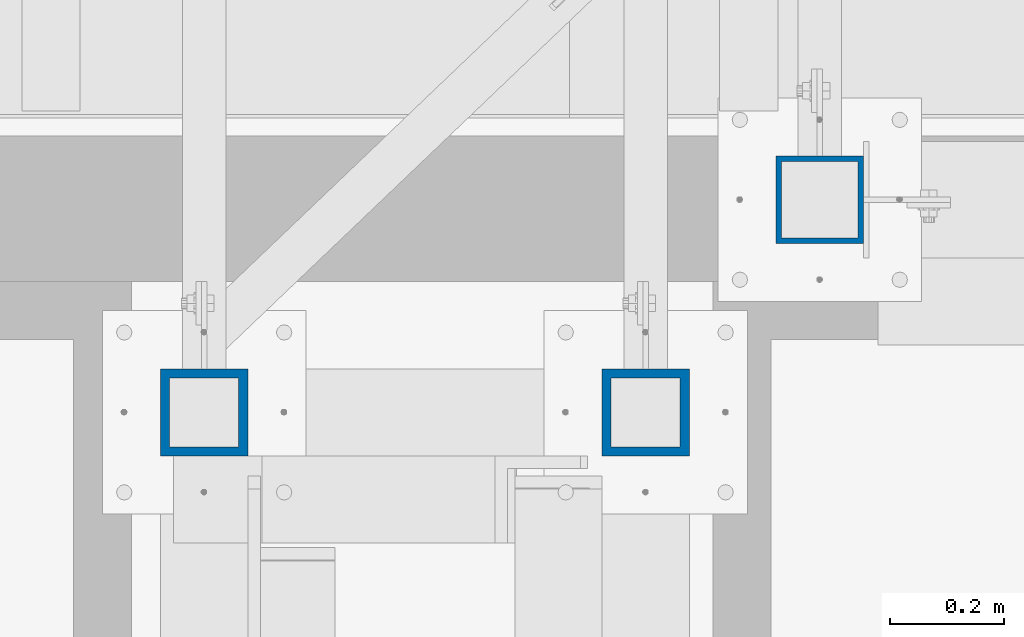
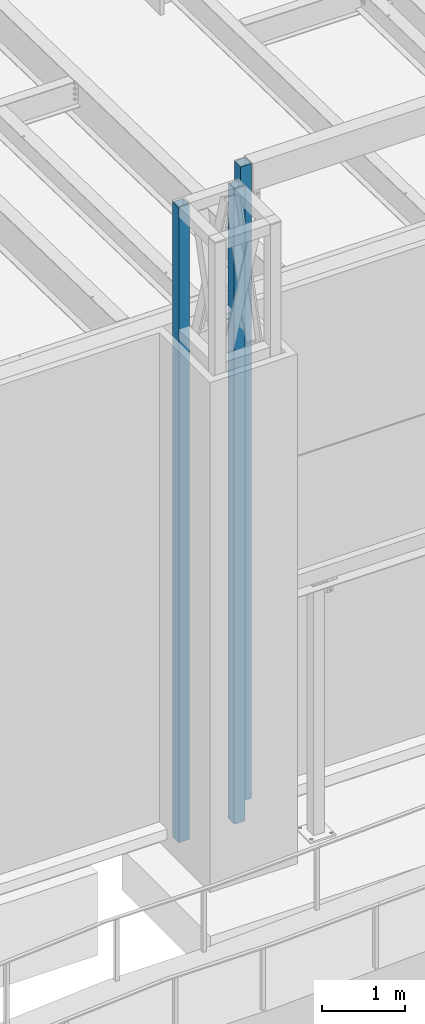
# One storey, part 880 of 1763: 3 columns, 2 elements without a shape of their own.
"""IFC2X3 building model written with IfcOpenShell, lengths in millimetres."""

from ifc_helpers import new_model, si_unit, frame, origin_with_axes, place, context, subcontext, project, spatial, faceted_brep, material, type_object, element, aggregate, save


model = new_model("IFC2X3")

# Units and contexts
model_context = context("Model", 3, precision=1e-05, world=origin_with_axes())
body_context = subcontext(model_context, "Body", "Model", "MODEL_VIEW")
ifc_project = project(units=[si_unit("LENGTHUNIT", "METRE", prefix="MILLI"), si_unit("AREAUNIT", "SQUARE_METRE"), si_unit("VOLUMEUNIT", "CUBIC_METRE"), si_unit("MASSUNIT", "GRAM", prefix="KILO"), si_unit("TIMEUNIT", "SECOND"), si_unit("PLANEANGLEUNIT", "RADIAN"), si_unit("SOLIDANGLEUNIT", "STERADIAN"), si_unit("THERMODYNAMICTEMPERATUREUNIT", "DEGREE_CELSIUS"), si_unit("LUMINOUSINTENSITYUNIT", "LUMEN")], contexts=[model_context])

# Site, building, storey
site_placement = place(None, origin_with_axes())
site = spatial("IfcSite", under=ifc_project, at=site_placement, CompositionType="ELEMENT")
building_placement = place(site_placement, origin_with_axes())
building = spatial("IfcBuilding", under=site, at=building_placement, Name="Undefined", CompositionType="ELEMENT")
storey_placement = place(building_placement, origin_with_axes())
storey = spatial("IfcBuildingStorey", under=building, at=storey_placement, Name="Undefined", CompositionType="ELEMENT", Elevation=0.0)

# Assembly, columns
assembly_1_placement = place(storey_placement, origin_with_axes())
assembly_1 = element("IfcElementAssembly", 1, at=assembly_1_placement, inside=storey, Name="FRAME", AssemblyPlace="NOTDEFINED", PredefinedType="RIGID_FRAME")
ifc_material = material()
column_type_1 = type_object("IfcColumnType", Name="HSS6X6X5/8", PredefinedType="NOTDEFINED")
column_1_placement = place(assembly_1_placement, frame((-69306.5116892775, -14579.5992675181, 5029.2), z_axis=(0.0, 1.0, 0.0), x_axis=(0.0, 0.0, 1.0)))
column_1 = element("IfcColumn", 2, at=column_1_placement, type_object=column_type_1, material=ifc_material, Name="COLUMN", ObjectType="HSS6X6X5/8", context=body_context, shape_type="Brep", body=[
    faceted_brep([(63.4999999999973, 60.3249999999971, -60.3250000000007), (63.4999999999973, -60.3249999999971, -60.3250000000007), (9429.74999873329, -60.3250000149637, -60.3250000000007), (9429.75000126672, 60.3249999850377, -60.3250000000007), (63.4999999999973, -60.3249999999971, 60.3250000000007), (9429.74999873329, -60.3250000149637, 60.3250000000007), (63.4999999999973, 60.3249999999971, 60.3250000000007), (9429.75000126672, 60.3249999850377, 60.3250000000007), (63.4999999999973, 76.1999999999971, -76.2000000000007), (63.4999999999973, 76.1999999999971, 76.2000000000007), (9429.75000000001, 76.1999999999971, 76.2000000000007), (9429.75000000001, 76.1999999999971, -76.2000000000007), (63.4999999999973, -76.1999999999971, 76.2000000000007), (9429.75000000001, -76.1999999999971, 76.2000000000007), (63.4999999999973, -76.1999999999971, -76.2000000000007), (9429.75000000001, -76.1999999999971, -76.2000000000007)], [[[0, 1, 2, 3]], [[1, 4, 5, 2]], [[4, 6, 7, 5]], [[6, 0, 3, 7]], [[8, 9, 10, 11]], [[9, 12, 13, 10]], [[12, 14, 15, 13]], [[14, 8, 11, 15]], [[13, 15, 11, 10], [5, 7, 3, 2]], [[14, 12, 9, 8], [6, 4, 1, 0]]]),
])
column_2_placement = place(assembly_1_placement, frame((-70078.03688459, -14579.5992675181, 5029.2), z_axis=(0.0, 1.0, 0.0), x_axis=(0.0, 0.0, 1.0)))
column_2 = element("IfcColumn", 3, at=column_2_placement, type_object=column_type_1, material=ifc_material, Name="COLUMN", ObjectType="HSS6X6X5/8", context=body_context, shape_type="Brep", body=[
    faceted_brep([(63.4999999999973, 60.3249999999971, -60.3250000000007), (63.4999999999973, -60.3249999999971, -60.3250000000007), (9429.74999873329, -60.3250000149637, -60.3250000000007), (9429.75000126672, 60.3249999850377, -60.3250000000007), (63.4999999999973, -60.3249999999971, 60.3250000000007), (9429.74999873329, -60.3250000149637, 60.3250000000007), (63.4999999999973, 60.3249999999971, 60.3250000000007), (9429.75000126672, 60.3249999850377, 60.3250000000007), (63.4999999999973, 76.1999999999971, -76.2000000000007), (63.4999999999973, 76.1999999999971, 76.2000000000007), (9429.75000000001, 76.1999999999971, 76.2000000000007), (9429.75000000001, 76.1999999999971, -76.2000000000007), (63.4999999999973, -76.1999999999971, 76.2000000000007), (9429.75000000001, -76.1999999999971, 76.2000000000007), (63.4999999999973, -76.1999999999971, -76.2000000000007), (9429.75000000001, -76.1999999999971, -76.2000000000007)], [[[0, 1, 2, 3]], [[1, 4, 5, 2]], [[4, 6, 7, 5]], [[6, 0, 3, 7]], [[8, 9, 10, 11]], [[9, 12, 13, 10]], [[12, 14, 15, 13]], [[14, 8, 11, 15]], [[13, 15, 11, 10], [5, 7, 3, 2]], [[14, 12, 9, 8], [6, 4, 1, 0]]]),
])
aggregate(assembly_1, [column_1, column_2])

# Assembly, column
assembly_2_placement = place(storey_placement, origin_with_axes())
assembly_2 = element("IfcElementAssembly", 4, at=assembly_2_placement, inside=storey, Name="COLUMN", AssemblyPlace="NOTDEFINED", PredefinedType="RIGID_FRAME")
column_type_2 = type_object("IfcColumnType", Name="HSS6X6X3/8", PredefinedType="NOTDEFINED")
column_3_placement = place(assembly_2_placement, frame((-69002.1577158888, -14208.1264769908, 5029.2), z_axis=(0.0, 1.0, 0.0), x_axis=(0.0, 0.0, 1.0)))
column_3 = element("IfcColumn", 5, at=column_3_placement, type_object=column_type_2, material=ifc_material, Name="COLUMN", ObjectType="HSS6X6X3/8", context=body_context, shape_type="Brep", body=[
    faceted_brep([(63.5000000000027, 66.6750000000029, -66.6749999999993), (63.5000000000027, -66.6750000000029, -66.6749999999993), (9429.75000000001, -66.6750000000029, -66.6749999999993), (9429.75000000001, 66.6750000000029, -66.6749999999993), (63.5000000000027, -66.6750000000029, 66.6749999999993), (9429.75000000001, -66.6750000000029, 66.6749999999993), (63.5000000000027, 66.6750000000029, 66.6749999999993), (9429.75000000001, 66.6750000000029, 66.6749999999993), (63.4999999999973, 76.1999999999971, -76.2000000000007), (63.4999999999973, 76.1999999999971, 76.2000000000007), (9429.75000000001, 76.1999999999971, 76.2000000000007), (9429.75000000001, 76.1999999999971, -76.2000000000007), (63.4999999999973, -76.1999999999971, 76.2000000000007), (9429.75000000001, -76.1999999999971, 76.2000000000007), (63.4999999999973, -76.1999999999971, -76.2000000000007), (9429.75000000001, -76.1999999999971, -76.2000000000007)], [[[0, 1, 2, 3]], [[1, 4, 5, 2]], [[4, 6, 7, 5]], [[6, 0, 3, 7]], [[8, 9, 10, 11]], [[9, 12, 13, 10]], [[12, 14, 15, 13]], [[14, 8, 11, 15]], [[13, 15, 11, 10], [5, 7, 3, 2]], [[14, 12, 9, 8], [6, 4, 1, 0]]]),
])
aggregate(assembly_2, [column_3])

save(model, "model.ifc")
